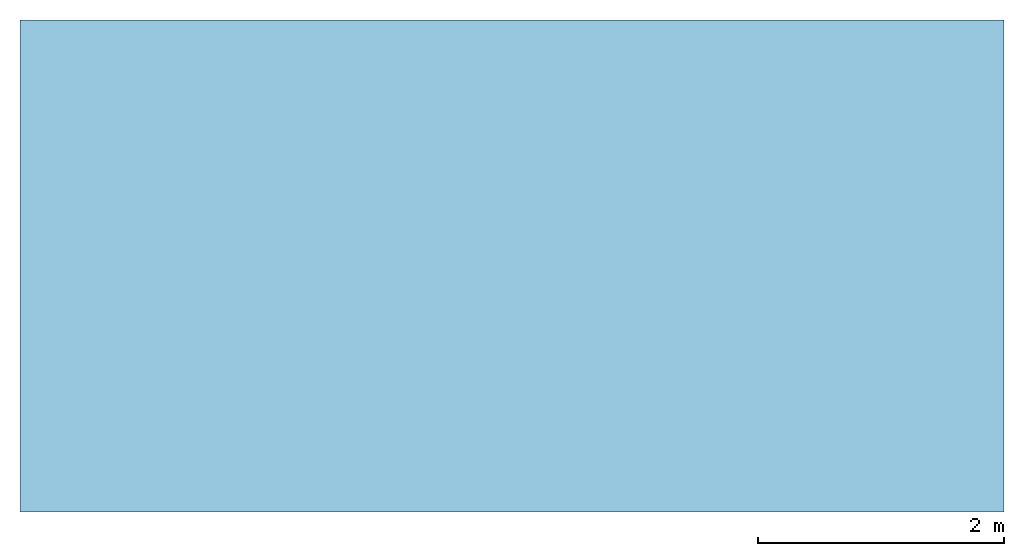
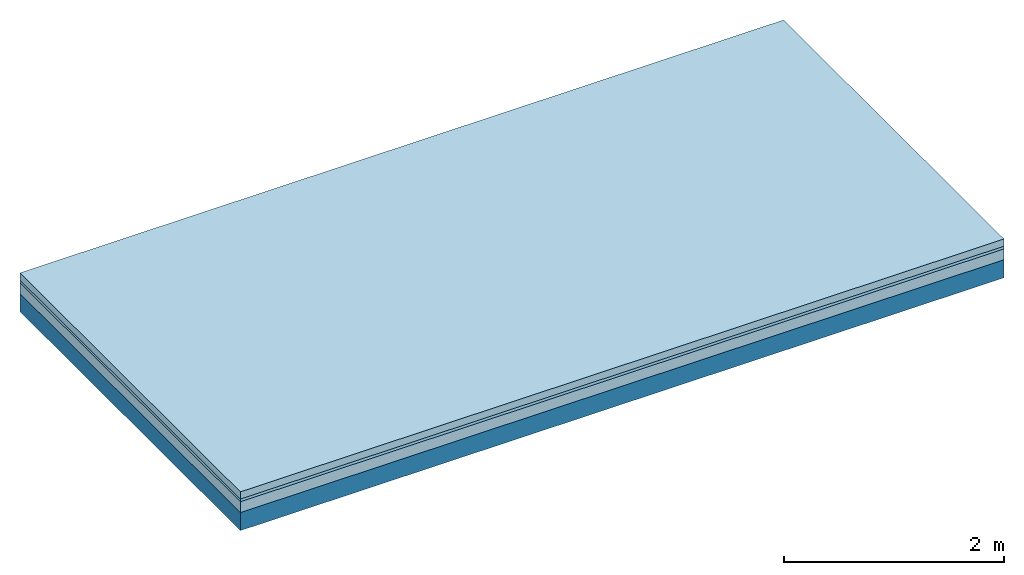
# One storey: 3 plates, 1 member, 1 element without a shape of its own.
"""IFC4 building model written with IfcOpenShell, lengths in metres."""

from ifc_helpers import new_model, si_unit, derived_unit, direction, frame, frame_2d, origin, origin_with_axes, place, context, project, spatial, rectangle, extrude, material, layer, layer_set, type_object, element, aggregate, save


model = new_model("IFC4")

# Units and contexts
plan_context = context("Plan", 3, precision=1e-05, world=origin(), true_north=direction((0.0, 1.0)))
model_context = context("Model", 3, precision=1e-05, world=origin(), true_north=direction((0.0, 1.0)))
ifc_project = project(units=[si_unit("LENGTHUNIT", "METRE"), derived_unit("SOUNDPRESSUREUNIT", [(si_unit("PRESSUREUNIT", "PASCAL", prefix="MICRO"), 0)]), si_unit("ENERGYUNIT", "JOULE", prefix="MEGA"), si_unit("MASSUNIT", "GRAM", prefix="KILO"), derived_unit("THERMALTRANSMITTANCEUNIT", [(si_unit("POWERUNIT", "WATT"), 1), (si_unit("AREAUNIT", "SQUARE_METRE"), -1), (si_unit("THERMODYNAMICTEMPERATUREUNIT", "KELVIN"), -1)]), derived_unit("AREADENSITYUNIT", [(si_unit("MASSUNIT", "GRAM", prefix="KILO"), 1), (si_unit("AREAUNIT", "SQUARE_METRE"), -1)]), derived_unit("USERDEFINED", [(si_unit("ENERGYUNIT", "JOULE", prefix="MEGA"), 1), (si_unit("AREAUNIT", "SQUARE_METRE"), -1)])], contexts=[plan_context, model_context])

# Site, building, storey
site = spatial("IfcSite", under=ifc_project)
building_placement = place(None, origin())
building = spatial("IfcBuilding", under=site, at=building_placement)
storey_placement = place(building_placement, origin())
storey = spatial("IfcBuildingStorey", under=building, at=storey_placement)

# Slab, member, plates
ifc_material_1 = material(Name="Cement screed", Category="04.006")
ifc_layer_1 = layer(ifc_material_1, 0.08, Name="On-material")
ifc_material_2 = material()
ifc_layer_2 = layer(ifc_material_2, 0.03, Name="Impact sound insulation")
ifc_material_3 = material(Category="03.011")
ifc_layer_3 = layer(ifc_material_3, 0.12, Name="on Supporting structure")
ifc_layer_4 = layer(None, 0.2, Name="Supporting structure")
ifc_layer_set = layer_set([ifc_layer_1, ifc_layer_2, ifc_layer_3, ifc_layer_4])
slab_type = type_object("IfcSlabType", Name="A1098", PredefinedType="NOTDEFINED", material=ifc_layer_set)
slab_placement = place(None, frame((0.0, 0.0, 0.0), z_axis=(0.0, 0.0, -1.0), x_axis=(1.0, 0.0, 0.0)))
slab = element("IfcSlab", 1, at=slab_placement, inside=storey, type_object=slab_type, material=ifc_layer_set, Name="Slab #1")
ifc_material_4 = material()
member_placement = place(slab_placement, origin())
member = element("IfcMember", 2, at=member_placement, material=ifc_material_4, Name="Supporting structure", context=plan_context, shape_type="SweptSolid", body=[
    extrude(rectangle(XDim=1.0, YDim=0.2, at=frame_2d((0.5, 0.1), x_axis=(1.0, 0.0))), frame((0.0, 4.0, 0.23), z_axis=(0.0, -1.0, 0.0), x_axis=(1.0, 0.0, 0.0)), (0.0, 0.0, 1.0), 4.0),
    extrude(rectangle(XDim=1.0, YDim=0.2, at=frame_2d((0.5, 0.1), x_axis=(1.0, 0.0))), frame((1.0, 4.0, 0.23), z_axis=(0.0, -1.0, 0.0), x_axis=(1.0, 0.0, 0.0)), (0.0, 0.0, 1.0), 4.0),
    extrude(rectangle(XDim=1.0, YDim=0.2, at=frame_2d((0.5, 0.1), x_axis=(1.0, 0.0))), frame((2.0, 4.0, 0.23), z_axis=(0.0, -1.0, 0.0), x_axis=(1.0, 0.0, 0.0)), (0.0, 0.0, 1.0), 4.0),
    extrude(rectangle(XDim=1.0, YDim=0.2, at=frame_2d((0.5, 0.1), x_axis=(1.0, 0.0))), frame((3.0, 4.0, 0.23), z_axis=(0.0, -1.0, 0.0), x_axis=(1.0, 0.0, 0.0)), (0.0, 0.0, 1.0), 4.0),
    extrude(rectangle(XDim=1.0, YDim=0.2, at=frame_2d((0.5, 0.1), x_axis=(1.0, 0.0))), frame((4.0, 4.0, 0.23), z_axis=(0.0, -1.0, 0.0), x_axis=(1.0, 0.0, 0.0)), (0.0, 0.0, 1.0), 4.0),
    extrude(rectangle(XDim=1.0, YDim=0.2, at=frame_2d((0.5, 0.1), x_axis=(1.0, 0.0))), frame((5.0, 4.0, 0.23), z_axis=(0.0, -1.0, 0.0), x_axis=(1.0, 0.0, 0.0)), (0.0, 0.0, 1.0), 4.0),
    extrude(rectangle(XDim=1.0, YDim=0.2, at=frame_2d((0.5, 0.1), x_axis=(1.0, 0.0))), frame((6.0, 4.0, 0.23), z_axis=(0.0, -1.0, 0.0), x_axis=(1.0, 0.0, 0.0)), (0.0, 0.0, 1.0), 4.0),
    extrude(rectangle(XDim=1.0, YDim=0.2, at=frame_2d((0.5, 0.1), x_axis=(1.0, 0.0))), frame((7.0, 4.0, 0.23), z_axis=(0.0, -1.0, 0.0), x_axis=(1.0, 0.0, 0.0)), (0.0, 0.0, 1.0), 4.0),
])
plate_1_placement = place(slab_placement, origin())
plate_1 = element("IfcPlate", 3, at=plate_1_placement, material=ifc_material_1, Name="On-material", context=plan_context, shape_type="SweptSolid", body=[
    extrude(rectangle(XDim=8.0, YDim=4.0, at=frame_2d((4.0, 2.0), x_axis=(1.0, 0.0))), origin_with_axes(), (0.0, 0.0, 1.0), 0.08),
])
plate_2_placement = place(slab_placement, origin())
plate_2 = element("IfcPlate", 4, at=plate_2_placement, material=ifc_material_2, Name="Impact sound insulation", context=plan_context, shape_type="SweptSolid", body=[
    extrude(rectangle(XDim=8.0, YDim=4.0, at=frame_2d((4.0, 2.0), x_axis=(1.0, 0.0))), frame((0.0, 0.0, 0.08), z_axis=(0.0, 0.0, 1.0), x_axis=(1.0, 0.0, 0.0)), (0.0, 0.0, 1.0), 0.03),
])
plate_3_placement = place(slab_placement, origin())
plate_3 = element("IfcPlate", 5, at=plate_3_placement, material=ifc_material_3, Name="on Supporting structure", context=plan_context, shape_type="SweptSolid", body=[
    extrude(rectangle(XDim=8.0, YDim=4.0, at=frame_2d((4.0, 2.0), x_axis=(1.0, 0.0))), frame((0.0, 0.0, 0.11), z_axis=(0.0, 0.0, 1.0), x_axis=(1.0, 0.0, 0.0)), (0.0, 0.0, 1.0), 0.12),
])
aggregate(slab, [plate_1, plate_2, plate_3, member])

save(model, "model.ifc")
